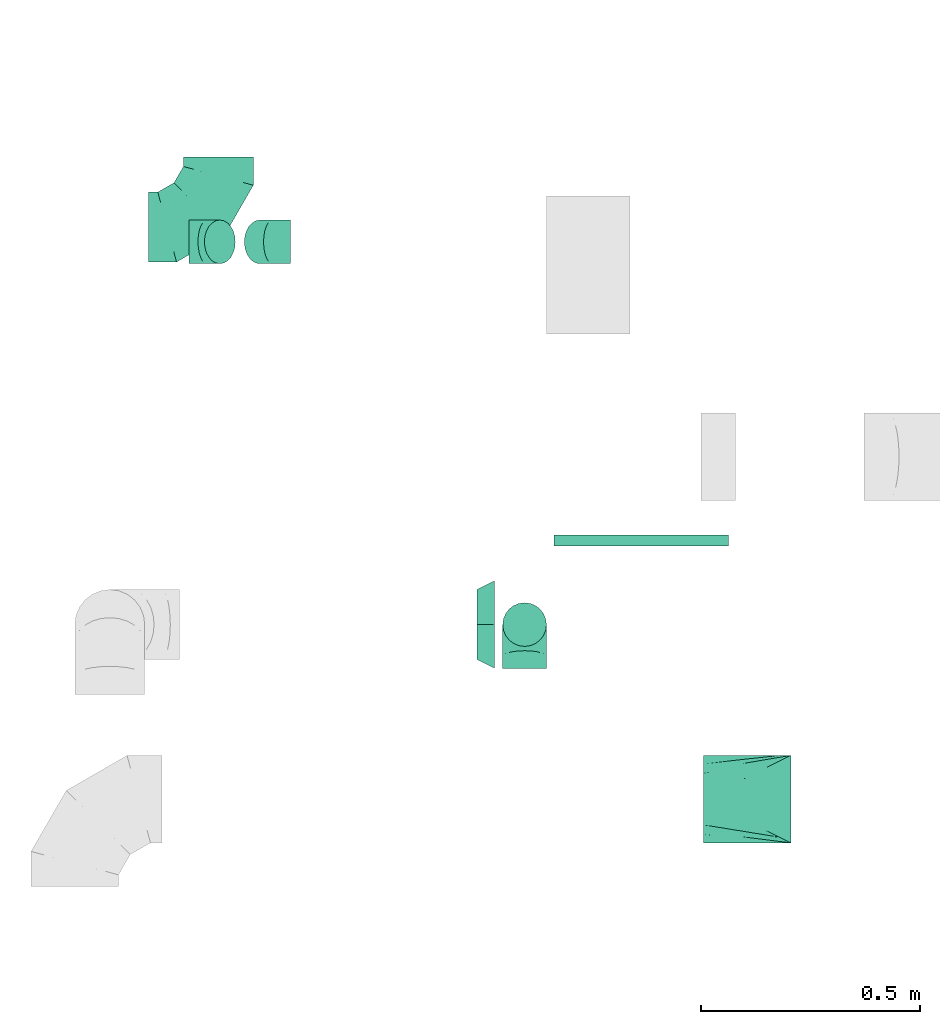
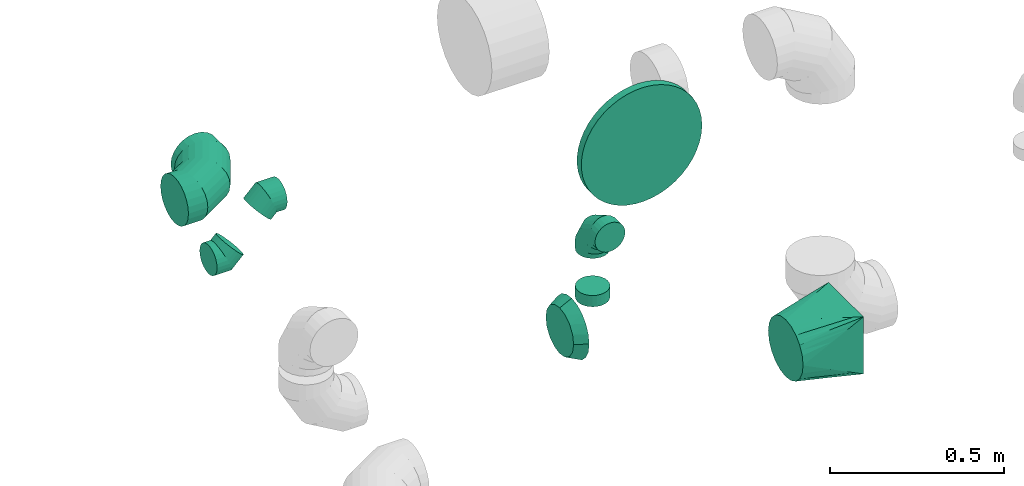
# One storey, part 19 of 62: 8 flow fittings.
"""IFC2X3 building model written with IfcOpenShell, lengths in millimetres."""

from ifc_helpers import new_model, entity, si_unit, converted_unit, derived_unit, direction, frame, origin, origin_2d_with_axis, place, context, subcontext, project, spatial, circle, extrude, faceted_brep, source, transform, mapped, material, type_object, type_shapes, element, save


model = new_model("IFC2X3")

# Units and contexts
model_context = context("Model", 3, precision=0.01, world=origin(), true_north=direction((6.12303176911189e-17, 1.0)))
body_context = subcontext(model_context, "Body", "Model", "MODEL_VIEW")
ifc_project = project(units=[si_unit("LENGTHUNIT", "METRE", prefix="MILLI"), si_unit("AREAUNIT", "SQUARE_METRE"), si_unit("VOLUMEUNIT", "CUBIC_METRE"), converted_unit("PLANEANGLEUNIT", "DEGREE", entity("IfcRatioMeasure", 0.0174532925199433), si_unit("PLANEANGLEUNIT", "RADIAN"), dimensions=[0, 0, 0, 0, 0, 0, 0]), si_unit("MASSUNIT", "GRAM", prefix="KILO"), derived_unit("MASSDENSITYUNIT", [(si_unit("MASSUNIT", "GRAM", prefix="KILO"), 1), (si_unit("LENGTHUNIT", "METRE"), -3)]), derived_unit("MOMENTOFINERTIAUNIT", [(si_unit("LENGTHUNIT", "METRE"), 4)]), si_unit("TIMEUNIT", "SECOND"), si_unit("FREQUENCYUNIT", "HERTZ"), si_unit("THERMODYNAMICTEMPERATUREUNIT", "DEGREE_CELSIUS"), derived_unit("THERMALTRANSMITTANCEUNIT", [(si_unit("MASSUNIT", "GRAM", prefix="KILO"), 1), (si_unit("THERMODYNAMICTEMPERATUREUNIT", "KELVIN"), -1), (si_unit("TIMEUNIT", "SECOND"), -3)]), derived_unit("VOLUMETRICFLOWRATEUNIT", [(si_unit("LENGTHUNIT", "METRE"), 3), (si_unit("TIMEUNIT", "SECOND"), -1)]), derived_unit("MASSFLOWRATEUNIT", [(si_unit("MASSUNIT", "GRAM", prefix="KILO"), 1), (si_unit("TIMEUNIT", "SECOND"), -1)]), derived_unit("ROTATIONALFREQUENCYUNIT", [(si_unit("TIMEUNIT", "SECOND"), -1)]), si_unit("ELECTRICCURRENTUNIT", "AMPERE"), si_unit("ELECTRICVOLTAGEUNIT", "VOLT"), si_unit("POWERUNIT", "WATT"), si_unit("FORCEUNIT", "NEWTON", prefix="KILO"), si_unit("ILLUMINANCEUNIT", "LUX"), si_unit("LUMINOUSFLUXUNIT", "LUMEN"), si_unit("LUMINOUSINTENSITYUNIT", "CANDELA"), derived_unit("USERDEFINED", [(si_unit("MASSUNIT", "GRAM", prefix="KILO"), -1), (si_unit("LENGTHUNIT", "METRE"), -2), (si_unit("TIMEUNIT", "SECOND"), 3), (si_unit("LUMINOUSFLUXUNIT", "LUMEN"), 1)]), derived_unit("LINEARVELOCITYUNIT", [(si_unit("LENGTHUNIT", "METRE"), 1), (si_unit("TIMEUNIT", "SECOND"), -1)]), si_unit("PRESSUREUNIT", "PASCAL"), derived_unit("USERDEFINED", [(si_unit("LENGTHUNIT", "METRE"), -2), (si_unit("MASSUNIT", "GRAM", prefix="KILO"), 1), (si_unit("TIMEUNIT", "SECOND"), -2)]), derived_unit("LINEARFORCEUNIT", [(si_unit("MASSUNIT", "GRAM", prefix="KILO"), 1), (si_unit("LENGTHUNIT", "METRE"), 1), (si_unit("TIMEUNIT", "SECOND"), -2), (si_unit("LENGTHUNIT", "METRE"), -1)]), derived_unit("PLANARFORCEUNIT", [(si_unit("MASSUNIT", "GRAM", prefix="KILO"), 1), (si_unit("LENGTHUNIT", "METRE"), 1), (si_unit("TIMEUNIT", "SECOND"), -2), (si_unit("LENGTHUNIT", "METRE"), -2)])], contexts=[model_context])

# Site, building, storey
site_placement = place(None, origin())
site = spatial("IfcSite", under=ifc_project, at=site_placement, CompositionType="ELEMENT")
building_placement = place(site_placement, origin())
building = spatial("IfcBuilding", under=site, at=building_placement, CompositionType="ELEMENT")
storey_placement = place(building_placement, frame((0.0, 0.0, 24000.0)))
storey = spatial("IfcBuildingStorey", under=building, at=storey_placement, CompositionType="ELEMENT", Elevation=24000.0)

# Flow fittings
ifc_material = material()
duct_fitting_type_1 = type_object("IfcDuctFittingType", PredefinedType="NOTDEFINED", material=ifc_material)
shared_shape_1 = source(origin(), body_context, "Body", "SweptSolid", [
    extrude(circle(Radius=199.999999999999, at=origin_2d_with_axis()), frame((0.0, 0.0, 0.0), z_axis=(1.0, 0.0, 0.0), x_axis=(0.0, 1.0, 0.0)), (0.0, 0.0, 1.0), 25.0000000000018),
])
type_shapes(duct_fitting_type_1, [shared_shape_1])
flow_fitting_1_placement = place(storey_placement, frame((24329.3, 9529.36, 3560.0), z_axis=(0.0, 0.0, 1.0), x_axis=(0.0, -1.0, 0.0)))
element("IfcFlowFitting", 1, at=flow_fitting_1_placement, inside=storey, type_object=duct_fitting_type_1, material=ifc_material, context=body_context, shape_type="MappedRepresentation", body=[
    mapped(shared_shape_1, transform((0.0, 0.0, 0.0), scale=1.0)),
])
duct_fitting_type_2 = type_object("IfcDuctFittingType", PredefinedType="NOTDEFINED", material=ifc_material)
shared_shape_2 = source(origin(), body_context, "Body", "Brep", [
    faceted_brep([(-160.0, 0.0, -80.0), (-160.0, -20.71, -77.27), (-160.0, -40.0, -69.28), (-160.0, -56.57, -56.57), (-160.0, -69.28, -40.0), (-160.0, -77.27, -20.71), (-160.0, -80.0, 0.0), (-160.0, -77.27, 20.71), (-160.0, -69.28, 40.0), (-160.0, -56.57, 56.57), (-160.0, -40.0, 69.28), (-160.0, -20.71, 77.27), (-160.0, 0.0, 80.0), (-160.0, 20.71, 77.27), (-160.0, 40.0, 69.28), (-160.0, 56.57, 56.57), (-160.0, 69.28, 40.0), (-160.0, 77.27, 20.71), (-160.0, 80.0, 0.0), (-160.0, 77.27, -20.71), (-160.0, 69.28, -40.0), (-160.0, 56.57, -56.57), (-160.0, 40.0, -69.28), (-160.0, 20.71, -77.27), (-122.68, 20.71, 77.27), (-127.85, 40.0, 69.28), (-117.13, 0.0, 80.0), (-132.29, 56.57, 56.57), (-137.83, 77.27, 20.71), (-138.56, 80.0, 0.0), (-135.69, 69.28, 40.0), (-135.69, 69.28, -40.0), (-132.29, 56.57, -56.57), (-137.83, 77.27, -20.71), (-122.68, 20.71, -77.27), (-117.13, 0.0, -80.0), (-127.85, 40.0, -69.28), (-111.58, -20.71, -77.27), (-106.41, -40.0, -69.28), (-101.97, -56.57, -56.57), (-98.56, -69.28, -40.0), (-96.42, -77.27, -20.71), (-95.69, -80.0, 0.0), (-96.42, -77.27, 20.71), (-98.56, -69.28, 40.0), (-101.97, -56.57, 56.57), (-106.41, -40.0, 69.28), (-111.58, -20.71, 77.27), (-58.03, 58.03, 77.27), (-72.15, 72.15, 69.28), (-42.87, 42.87, 80.0), (-84.28, 84.28, 56.57), (-93.59, 93.59, 40.0), (-99.44, 99.44, 20.71), (-101.44, 101.44, 0.0), (-99.44, 99.44, -20.71), (-93.59, 93.59, -40.0), (-84.28, 84.28, -56.57), (-58.03, 58.03, -77.27), (-42.87, 42.87, -80.0), (-72.15, 72.15, -69.28), (-27.71, 27.71, -77.27), (-13.59, 13.59, -69.28), (-1.46, 1.46, -56.57), (7.85, -7.85, -40.0), (13.7, -13.7, -20.71), (15.69, -15.69, 0.0), (13.7, -13.7, 20.71), (7.85, -7.85, 40.0), (-1.46, 1.46, 56.57), (-13.59, 13.59, 69.28), (-27.71, 27.71, 77.27), (-20.71, 122.68, 77.27), (-40.0, 127.85, 69.28), (0.0, 117.13, 80.0), (-56.57, 132.29, 56.57), (-69.28, 135.69, 40.0), (-77.27, 137.83, 20.71), (-80.0, 138.56, 0.0), (-77.27, 137.83, -20.71), (-69.28, 135.69, -40.0), (-56.57, 132.29, -56.57), (-20.71, 122.68, -77.27), (0.0, 117.13, -80.0), (-40.0, 127.85, -69.28), (20.71, 111.58, -77.27), (40.0, 106.41, -69.28), (56.57, 101.97, -56.57), (69.28, 98.56, -40.0), (77.27, 96.42, -20.71), (80.0, 95.69, 0.0), (77.27, 96.42, 20.71), (69.28, 98.56, 40.0), (56.57, 101.97, 56.57), (40.0, 106.41, 69.28), (20.71, 111.58, 77.27), (-20.71, 160.0, -77.27), (-40.0, 160.0, -69.28), (-56.57, 160.0, -56.57), (-69.28, 160.0, -40.0), (-77.27, 160.0, -20.71), (-80.0, 160.0, 0.0), (-77.27, 160.0, 20.71), (-69.28, 160.0, 40.0), (-56.57, 160.0, 56.57), (-40.0, 160.0, 69.28), (-20.71, 160.0, 77.27), (0.0, 160.0, 80.0), (20.71, 160.0, 77.27), (40.0, 160.0, 69.28), (56.57, 160.0, 56.57), (69.28, 160.0, 40.0), (77.27, 160.0, 20.71), (80.0, 160.0, 0.0), (77.27, 160.0, -20.71), (69.28, 160.0, -40.0), (56.57, 160.0, -56.57), (40.0, 160.0, -69.28), (20.71, 160.0, -77.27), (0.0, 160.0, -80.0)], [[[0, 1, 2, 3, 4, 5, 6, 7, 8, 9, 10, 11, 12, 13, 14, 15, 16, 17, 18, 19, 20, 21, 22, 23]], [[24, 25, 14, 13]], [[26, 24, 13, 12]], [[14, 25, 27, 15]], [[28, 29, 18, 17]], [[30, 28, 17, 16]], [[15, 27, 30, 16]], [[20, 31, 32, 21]], [[33, 31, 20, 19]], [[18, 29, 33, 19]], [[34, 35, 0, 23]], [[36, 34, 23, 22]], [[32, 36, 22, 21]], [[1, 0, 35, 37]], [[2, 1, 37, 38]], [[3, 2, 38, 39]], [[5, 4, 40, 41]], [[6, 5, 41, 42]], [[39, 40, 4, 3]], [[6, 42, 43, 7]], [[7, 43, 44, 8]], [[8, 44, 45, 9]], [[9, 45, 46, 10]], [[10, 46, 47, 11]], [[26, 12, 11, 47]], [[48, 49, 25, 24]], [[50, 48, 24, 26]], [[27, 25, 49, 51]], [[52, 53, 28, 30]], [[51, 52, 30, 27]], [[29, 28, 53, 54]], [[55, 56, 31, 33]], [[54, 55, 33, 29]], [[32, 31, 56, 57]], [[58, 59, 35, 34]], [[60, 58, 34, 36]], [[57, 60, 36, 32]], [[37, 35, 59, 61]], [[38, 37, 61, 62]], [[39, 38, 62, 63]], [[41, 40, 64, 65]], [[42, 41, 65, 66]], [[63, 64, 40, 39]], [[43, 42, 66, 67]], [[44, 43, 67, 68]], [[68, 69, 45, 44]], [[46, 45, 69, 70]], [[47, 46, 70, 71]], [[26, 47, 71, 50]], [[72, 73, 49, 48]], [[74, 72, 48, 50]], [[51, 49, 73, 75]], [[76, 77, 53, 52]], [[75, 76, 52, 51]], [[54, 53, 77, 78]], [[79, 80, 56, 55]], [[78, 79, 55, 54]], [[57, 56, 80, 81]], [[82, 83, 59, 58]], [[84, 82, 58, 60]], [[81, 84, 60, 57]], [[61, 59, 83, 85]], [[62, 61, 85, 86]], [[63, 62, 86, 87]], [[65, 64, 88, 89]], [[66, 65, 89, 90]], [[87, 88, 64, 63]], [[67, 66, 90, 91]], [[68, 67, 91, 92]], [[92, 93, 69, 68]], [[70, 69, 93, 94]], [[71, 70, 94, 95]], [[50, 71, 95, 74]], [[96, 97, 98, 99, 100, 101, 102, 103, 104, 105, 106, 107, 108, 109, 110, 111, 112, 113, 114, 115, 116, 117, 118, 119]], [[72, 74, 107, 106]], [[73, 72, 106, 105]], [[75, 73, 105, 104]], [[77, 76, 103, 102]], [[78, 77, 102, 101]], [[75, 104, 103, 76]], [[78, 101, 100, 79]], [[79, 100, 99, 80]], [[80, 99, 98, 81]], [[84, 97, 96, 82]], [[82, 96, 119, 83]], [[84, 81, 98, 97]], [[118, 117, 86, 85]], [[119, 118, 85, 83]], [[116, 87, 86, 117]], [[88, 115, 114, 89]], [[89, 114, 113, 90]], [[115, 88, 87, 116]], [[112, 111, 92, 91]], [[113, 112, 91, 90]], [[111, 110, 93, 92]], [[95, 94, 109, 108]], [[74, 95, 108, 107]], [[110, 109, 94, 93]]]),
])
type_shapes(duct_fitting_type_2, [shared_shape_2])
flow_fitting_2_placement = place(storey_placement, frame((23362.42, 10233.8, 3320.0)))
element("IfcFlowFitting", 2, at=flow_fitting_2_placement, inside=storey, type_object=duct_fitting_type_2, material=ifc_material, context=body_context, shape_type="MappedRepresentation", body=[
    mapped(shared_shape_2, transform((0.0, 0.0, 0.0), scale=1.0)),
])
duct_fitting_type_3 = type_object("IfcDuctFittingType", PredefinedType="NOTDEFINED", material=ifc_material)
shared_shape_3 = source(origin(), body_context, "Body", "Brep", [
    faceted_brep([(-100.0, 0.0, -50.0), (-100.0, -12.94, -48.3), (-100.0, -25.0, -43.3), (-100.0, -35.36, -35.36), (-100.0, -43.3, -25.0), (-100.0, -48.3, -12.94), (-100.0, -50.0, 0.0), (-100.0, -48.3, 12.94), (-100.0, -43.3, 25.0), (-100.0, -35.36, 35.36), (-100.0, -25.0, 43.3), (-100.0, -12.94, 48.3), (-100.0, 0.0, 50.0), (-100.0, 12.94, 48.3), (-100.0, 25.0, 43.3), (-100.0, 35.36, 35.36), (-100.0, 43.3, 25.0), (-100.0, 48.3, 12.94), (-100.0, 50.0, 0.0), (-100.0, 48.3, -12.94), (-100.0, 43.3, -25.0), (-100.0, 35.36, -35.36), (-100.0, 25.0, -43.3), (-100.0, 12.94, -48.3), (-76.67, 12.94, 48.3), (-79.9, 25.0, 43.3), (-73.21, 0.0, 50.0), (-82.68, 35.36, 35.36), (-86.15, 48.3, 12.94), (-86.6, 50.0, 0.0), (-84.81, 43.3, 25.0), (-84.81, 43.3, -25.0), (-82.68, 35.36, -35.36), (-86.15, 48.3, -12.94), (-76.67, 12.94, -48.3), (-73.21, 0.0, -50.0), (-79.9, 25.0, -43.3), (-69.74, -12.94, -48.3), (-66.51, -25.0, -43.3), (-63.73, -35.36, -35.36), (-61.6, -43.3, -25.0), (-60.26, -48.3, -12.94), (-59.81, -50.0, 0.0), (-60.26, -48.3, 12.94), (-61.6, -43.3, 25.0), (-63.73, -35.36, 35.36), (-66.51, -25.0, 43.3), (-69.74, -12.94, 48.3), (-36.27, 36.27, 48.3), (-45.1, 45.1, 43.3), (-26.79, 26.79, 50.0), (-52.68, 52.68, 35.36), (-58.49, 58.49, 25.0), (-62.15, 62.15, 12.94), (-63.4, 63.4, 0.0), (-62.15, 62.15, -12.94), (-58.49, 58.49, -25.0), (-52.68, 52.68, -35.36), (-36.27, 36.27, -48.3), (-26.79, 26.79, -50.0), (-45.1, 45.1, -43.3), (-17.32, 17.32, -48.3), (-8.49, 8.49, -43.3), (-0.91, 0.91, -35.36), (4.9, -4.9, -25.0), (8.56, -8.56, -12.94), (9.81, -9.81, 0.0), (8.56, -8.56, 12.94), (4.9, -4.9, 25.0), (-0.91, 0.91, 35.36), (-8.49, 8.49, 43.3), (-17.32, 17.32, 48.3), (-12.94, 76.67, 48.3), (-25.0, 79.9, 43.3), (0.0, 73.21, 50.0), (-35.36, 82.68, 35.36), (-43.3, 84.81, 25.0), (-48.3, 86.15, 12.94), (-50.0, 86.6, 0.0), (-48.3, 86.15, -12.94), (-43.3, 84.81, -25.0), (-35.36, 82.68, -35.36), (-12.94, 76.67, -48.3), (0.0, 73.21, -50.0), (-25.0, 79.9, -43.3), (12.94, 69.74, -48.3), (25.0, 66.51, -43.3), (35.36, 63.73, -35.36), (43.3, 61.6, -25.0), (48.3, 60.26, -12.94), (50.0, 59.81, 0.0), (48.3, 60.26, 12.94), (43.3, 61.6, 25.0), (35.36, 63.73, 35.36), (25.0, 66.51, 43.3), (12.94, 69.74, 48.3), (-12.94, 100.0, -48.3), (-25.0, 100.0, -43.3), (-35.36, 100.0, -35.36), (-43.3, 100.0, -25.0), (-48.3, 100.0, -12.94), (-50.0, 100.0, 0.0), (-48.3, 100.0, 12.94), (-43.3, 100.0, 25.0), (-35.36, 100.0, 35.36), (-25.0, 100.0, 43.3), (-12.94, 100.0, 48.3), (0.0, 100.0, 50.0), (12.94, 100.0, 48.3), (25.0, 100.0, 43.3), (35.36, 100.0, 35.36), (43.3, 100.0, 25.0), (48.3, 100.0, 12.94), (50.0, 100.0, 0.0), (48.3, 100.0, -12.94), (43.3, 100.0, -25.0), (35.36, 100.0, -35.36), (25.0, 100.0, -43.3), (12.94, 100.0, -48.3), (0.0, 100.0, -50.0)], [[[0, 1, 2, 3, 4, 5, 6, 7, 8, 9, 10, 11, 12, 13, 14, 15, 16, 17, 18, 19, 20, 21, 22, 23]], [[24, 25, 14, 13]], [[26, 24, 13, 12]], [[14, 25, 27, 15]], [[28, 29, 18, 17]], [[30, 28, 17, 16]], [[15, 27, 30, 16]], [[20, 31, 32, 21]], [[33, 31, 20, 19]], [[18, 29, 33, 19]], [[34, 35, 0, 23]], [[36, 34, 23, 22]], [[32, 36, 22, 21]], [[2, 1, 37, 38]], [[3, 2, 38, 39]], [[0, 35, 37, 1]], [[5, 4, 40, 41]], [[6, 5, 41, 42]], [[3, 39, 40, 4]], [[6, 42, 43, 7]], [[7, 43, 44, 8]], [[8, 44, 45, 9]], [[10, 46, 47, 11]], [[11, 47, 26, 12]], [[10, 9, 45, 46]], [[48, 49, 25, 24]], [[50, 48, 24, 26]], [[27, 25, 49, 51]], [[52, 53, 28, 30]], [[51, 52, 30, 27]], [[29, 28, 53, 54]], [[55, 56, 31, 33]], [[54, 55, 33, 29]], [[57, 32, 31, 56]], [[58, 59, 35, 34]], [[60, 58, 34, 36]], [[57, 60, 36, 32]], [[37, 35, 59, 61]], [[38, 37, 61, 62]], [[39, 38, 62, 63]], [[41, 40, 64, 65]], [[42, 41, 65, 66]], [[63, 64, 40, 39]], [[43, 42, 66, 67]], [[44, 43, 67, 68]], [[68, 69, 45, 44]], [[46, 45, 69, 70]], [[47, 46, 70, 71]], [[26, 47, 71, 50]], [[72, 73, 49, 48]], [[74, 72, 48, 50]], [[51, 49, 73, 75]], [[76, 77, 53, 52]], [[75, 76, 52, 51]], [[54, 53, 77, 78]], [[79, 80, 56, 55]], [[78, 79, 55, 54]], [[81, 57, 56, 80]], [[82, 83, 59, 58]], [[84, 82, 58, 60]], [[81, 84, 60, 57]], [[61, 59, 83, 85]], [[62, 61, 85, 86]], [[63, 62, 86, 87]], [[65, 64, 88, 89]], [[66, 65, 89, 90]], [[87, 88, 64, 63]], [[67, 66, 90, 91]], [[68, 67, 91, 92]], [[92, 93, 69, 68]], [[70, 69, 93, 94]], [[71, 70, 94, 95]], [[50, 71, 95, 74]], [[96, 97, 98, 99, 100, 101, 102, 103, 104, 105, 106, 107, 108, 109, 110, 111, 112, 113, 114, 115, 116, 117, 118, 119]], [[72, 74, 107, 106]], [[73, 72, 106, 105]], [[75, 73, 105, 104]], [[77, 76, 103, 102]], [[78, 77, 102, 101]], [[75, 104, 103, 76]], [[78, 101, 100, 79]], [[79, 100, 99, 80]], [[80, 99, 98, 81]], [[96, 119, 83, 82]], [[97, 96, 82, 84]], [[84, 81, 98, 97]], [[83, 119, 118, 85]], [[85, 118, 117, 86]], [[86, 117, 116, 87]], [[88, 115, 114, 89]], [[89, 114, 113, 90]], [[87, 116, 115, 88]], [[91, 90, 113, 112]], [[92, 91, 112, 111]], [[93, 92, 111, 110]], [[95, 94, 109, 108]], [[74, 95, 108, 107]], [[110, 109, 94, 93]]]),
])
type_shapes(duct_fitting_type_3, [shared_shape_3])
flow_fitting_3_placement = place(storey_placement, frame((24062.93, 9324.41, 3500.0), z_axis=(1.0, 0.0, 0.0), x_axis=(0.0, 0.0, 1.0)))
element("IfcFlowFitting", 3, at=flow_fitting_3_placement, inside=storey, type_object=duct_fitting_type_3, material=ifc_material, context=body_context, shape_type="MappedRepresentation", body=[
    mapped(shared_shape_3, transform((0.0, 0.0, 0.0), scale=1.0)),
])
duct_fitting_type_4 = type_object("IfcDuctFittingType", PredefinedType="NOTDEFINED", material=ifc_material)
shared_shape_4 = source(origin(), body_context, "Body", "Brep", [
    faceted_brep([(-41.42, 0.0, -50.0), (-41.42, -12.94, -48.3), (-41.42, -25.0, -43.3), (-41.42, -35.36, -35.36), (-41.42, -43.3, -25.0), (-41.42, -48.3, -12.94), (-41.42, -50.0, 0.0), (-41.42, -48.3, 12.94), (-41.42, -43.3, 25.0), (-41.42, -35.36, 35.36), (-41.42, -25.0, 43.3), (-41.42, -12.94, 48.3), (-41.42, 0.0, 50.0), (-41.42, 12.94, 48.3), (-41.42, 25.0, 43.3), (-41.42, 35.36, 35.36), (-41.42, 43.3, 25.0), (-41.42, 48.3, 12.94), (-41.42, 50.0, 0.0), (-41.42, 48.3, -12.94), (-41.42, 43.3, -25.0), (-41.42, 35.36, -35.36), (-41.42, 25.0, -43.3), (-41.42, 12.94, -48.3), (-5.36, 12.94, 48.3), (-10.36, 25.0, 43.3), (0.0, 0.0, 50.0), (-14.64, 35.36, 35.36), (-20.0, 48.3, 12.94), (-20.71, 50.0, 0.0), (-17.94, 43.3, 25.0), (-17.94, 43.3, -25.0), (-14.64, 35.36, -35.36), (-20.0, 48.3, -12.94), (-5.36, 12.94, -48.3), (0.0, 0.0, -50.0), (-10.36, 25.0, -43.3), (5.36, -12.94, -48.3), (10.36, -25.0, -43.3), (14.64, -35.36, -35.36), (17.94, -43.3, -25.0), (20.0, -48.3, -12.94), (20.71, -50.0, 0.0), (20.0, -48.3, 12.94), (17.94, -43.3, 25.0), (14.64, -35.36, 35.36), (10.36, -25.0, 43.3), (5.36, -12.94, 48.3), (29.29, 29.29, 50.0), (20.14, 38.44, 48.3), (11.61, 46.97, 43.3), (4.29, 54.29, 35.36), (-1.33, 59.91, 25.0), (-4.86, 63.44, 12.94), (-6.07, 64.64, 0.0), (-4.86, 63.44, -12.94), (-1.33, 59.91, -25.0), (4.29, 54.29, -35.36), (11.61, 46.97, -43.3), (20.14, 38.44, -48.3), (29.29, 29.29, -50.0), (38.44, 20.14, -48.3), (46.97, 11.61, -43.3), (54.29, 4.29, -35.36), (59.91, -1.33, -25.0), (63.44, -4.86, -12.94), (64.64, -6.07, 0.0), (63.44, -4.86, 12.94), (59.91, -1.33, 25.0), (54.29, 4.29, 35.36), (46.97, 11.61, 43.3), (38.44, 20.14, 48.3)], [[[0, 1, 2, 3, 4, 5, 6, 7, 8, 9, 10, 11, 12, 13, 14, 15, 16, 17, 18, 19, 20, 21, 22, 23]], [[24, 25, 14, 13]], [[26, 24, 13, 12]], [[14, 25, 27, 15]], [[28, 29, 18, 17]], [[30, 28, 17, 16]], [[16, 15, 27, 30]], [[20, 31, 32, 21]], [[33, 31, 20, 19]], [[18, 29, 33, 19]], [[34, 35, 0, 23]], [[36, 34, 23, 22]], [[32, 36, 22, 21]], [[1, 0, 35, 37]], [[2, 1, 37, 38]], [[38, 39, 3, 2]], [[5, 4, 40, 41]], [[6, 5, 41, 42]], [[39, 40, 4, 3]], [[6, 42, 43, 7]], [[7, 43, 44, 8]], [[8, 44, 45, 9]], [[9, 45, 46, 10]], [[10, 46, 47, 11]], [[26, 12, 11, 47]], [[24, 26, 48, 49]], [[25, 24, 49, 50]], [[27, 25, 50, 51]], [[28, 30, 52, 53]], [[29, 28, 53, 54]], [[27, 51, 52, 30]], [[29, 54, 55, 33]], [[33, 55, 56, 31]], [[31, 56, 57, 32]], [[36, 58, 59, 34]], [[34, 59, 60, 35]], [[36, 32, 57, 58]], [[61, 62, 38, 37]], [[60, 61, 37, 35]], [[63, 39, 38, 62]], [[40, 64, 65, 41]], [[41, 65, 66, 42]], [[64, 40, 39, 63]], [[43, 42, 66, 67]], [[44, 43, 67, 68]], [[68, 69, 45, 44]], [[47, 46, 70, 71]], [[26, 47, 71, 48]], [[69, 70, 46, 45]], [[59, 58, 57, 56, 55, 54, 53, 52, 51, 50, 49, 48, 71, 70, 69, 68, 67, 66, 65, 64, 63, 62, 61, 60]]]),
])
type_shapes(duct_fitting_type_4, [shared_shape_4])
for number, where, z_axis, x_axis in (
    (4, (23336.45, 10199.94, 3100.0), (0.0, -1.0, 0.0), (1.0, 0.0, 0.0)),
    (5, (23486.45, 10199.94, 3250.0), (0.0, 1.0, 0.0), (0.707106781186481, 0.0, 0.707106781186615)),
):
    element("IfcFlowFitting", number, at=place(storey_placement, frame(where, z_axis=z_axis, x_axis=x_axis)), inside=storey, type_object=duct_fitting_type_4, material=ifc_material, context=body_context, shape_type="MappedRepresentation", body=[
        mapped(shared_shape_4, transform((0.0, 0.0, 0.0), scale=1.0)),
    ])
duct_fitting_type_5 = type_object("IfcDuctFittingType", PredefinedType="NOTDEFINED", material=ifc_material)
shared_shape_5 = source(origin(), body_context, "Body", "Brep", [
    faceted_brep([(40.0, -73.91, 30.61), (40.0, -76.96, 15.31), (40.0, -80.0, 0.0), (40.0, -76.96, -15.31), (40.0, -73.91, -30.61), (40.0, -65.24, -43.59), (40.0, -56.57, -56.57), (40.0, -43.59, -65.24), (40.0, -30.61, -73.91), (40.0, -15.31, -76.96), (40.0, 0.0, -80.0), (40.0, 15.31, -76.96), (40.0, 30.61, -73.91), (40.0, 43.59, -65.24), (40.0, 56.57, -56.57), (40.0, 65.24, -43.59), (40.0, 73.91, -30.61), (40.0, 76.96, -15.31), (40.0, 80.0, 0.0), (40.0, 76.96, 15.31), (40.0, 73.91, 30.61), (40.0, 65.24, 43.59), (40.0, 56.57, 56.57), (40.0, 43.59, 65.24), (40.0, 30.61, 73.91), (40.0, 15.31, 76.96), (40.0, 0.0, 80.0), (40.0, -15.31, 76.96), (40.0, -30.61, 73.91), (40.0, -43.59, 65.24), (40.0, -56.57, 56.57), (40.0, -65.24, 43.59), (0.0, -100.0, 0.0), (0.0, -95.11, 30.9), (0.0, -80.9, 58.78), (0.0, -58.78, 80.9), (0.0, -30.9, 95.11), (0.0, 0.0, 100.0), (0.0, 30.9, 95.11), (0.0, 58.78, 80.9), (0.0, 80.9, 58.78), (0.0, 95.11, 30.9), (0.0, 100.0, 0.0), (0.0, 95.11, -30.9), (0.0, 80.9, -58.78), (0.0, 58.78, -80.9), (0.0, 30.9, -95.11), (0.0, 0.0, -100.0), (0.0, -30.9, -95.11), (0.0, -58.78, -80.9), (0.0, -80.9, -58.78), (0.0, -95.11, -30.9)], [[[0, 1, 2, 3, 4, 5, 6, 7, 8, 9, 10, 11, 12, 13, 14, 15, 16, 17, 18, 19, 20, 21, 22, 23, 24, 25, 26, 27, 28, 29, 30, 31]], [[32, 33, 34, 35, 36, 37, 38, 39, 40, 41, 42, 43, 44, 45, 46, 47, 48, 49, 50, 51]], [[37, 25, 38]], [[25, 24, 38]], [[24, 39, 38]], [[41, 20, 19]], [[25, 37, 26]], [[39, 24, 23, 22]], [[42, 19, 18]], [[20, 40, 22, 21]], [[41, 40, 20]], [[42, 41, 19]], [[22, 40, 39]], [[32, 1, 33]], [[1, 0, 33]], [[0, 34, 33]], [[36, 28, 27]], [[1, 32, 2]], [[34, 0, 31, 30]], [[37, 27, 26]], [[28, 35, 30, 29]], [[36, 35, 28]], [[37, 36, 27]], [[30, 35, 34]], [[47, 9, 48]], [[9, 8, 48]], [[8, 49, 48]], [[51, 4, 3]], [[9, 47, 10]], [[49, 8, 7, 6]], [[32, 3, 2]], [[4, 50, 6, 5]], [[51, 50, 4]], [[32, 51, 3]], [[6, 50, 49]], [[42, 17, 43]], [[17, 16, 43]], [[16, 44, 43]], [[46, 12, 11]], [[17, 42, 18]], [[44, 16, 15, 14]], [[47, 11, 10]], [[12, 45, 14, 13]], [[46, 45, 12]], [[47, 46, 11]], [[14, 45, 44]]]),
])
type_shapes(duct_fitting_type_5, [shared_shape_5])
flow_fitting_4_placement = place(storey_placement, frame((23993.85, 9324.41, 3150.0), z_axis=(0.0, 0.0, 1.0), x_axis=(-1.0, 0.0, 0.0)))
element("IfcFlowFitting", 6, at=flow_fitting_4_placement, inside=storey, type_object=duct_fitting_type_5, material=ifc_material, context=body_context, shape_type="MappedRepresentation", body=[
    mapped(shared_shape_5, transform((0.0, 0.0, 0.0), scale=1.0)),
])
duct_fitting_type_6 = type_object("IfcDuctFittingType", PredefinedType="NOTDEFINED", material=ifc_material)
shared_shape_6 = source(origin(), body_context, "Body", "Brep", [
    faceted_brep([(20.0, 12.94, -48.3), (20.0, 25.0, -43.3), (20.0, 35.36, -35.36), (20.0, 43.3, -25.0), (20.0, 48.3, -12.94), (20.0, 50.0, 0.0), (20.0, 48.3, 12.94), (20.0, 43.3, 25.0), (20.0, 35.36, 35.36), (20.0, 25.0, 43.3), (20.0, 12.94, 48.3), (20.0, 0.0, 50.0), (20.0, -12.94, 48.3), (20.0, -25.0, 43.3), (20.0, -35.36, 35.36), (20.0, -43.3, 25.0), (20.0, -48.3, 12.94), (20.0, -50.0, 0.0), (20.0, -48.3, -12.94), (20.0, -43.3, -25.0), (20.0, -35.36, -35.36), (20.0, -25.0, -43.3), (20.0, -12.94, -48.3), (20.0, 0.0, -50.0), (0.0, 0.0, 50.0), (0.0, 12.94, 48.3), (-19.49, 12.94, 48.3), (-19.49, 0.0, 50.0), (0.0, 25.0, 43.3), (-19.49, 25.0, 43.3), (0.0, 35.36, 35.36), (-19.49, 35.36, 35.36), (0.0, 43.3, 25.0), (0.0, 48.3, 12.94), (-19.49, 48.3, 12.94), (-19.49, 43.3, 25.0), (0.0, 50.0, 0.0), (-19.49, 50.0, 0.0), (0.0, 48.3, -12.94), (-19.49, 48.3, -12.94), (0.0, 43.3, -25.0), (-19.49, 43.3, -25.0), (0.0, 35.36, -35.36), (-19.49, 35.36, -35.36), (0.0, 25.0, -43.3), (0.0, 12.94, -48.3), (-19.49, 12.94, -48.3), (-19.49, 25.0, -43.3), (0.0, 0.0, -50.0), (-19.49, 0.0, -50.0), (0.0, -12.94, -48.3), (-19.49, -12.94, -48.3), (0.0, -25.0, -43.3), (-19.49, -25.0, -43.3), (0.0, -35.36, -35.36), (-19.49, -35.36, -35.36), (0.0, -43.3, -25.0), (0.0, -48.3, -12.94), (-19.49, -48.3, -12.94), (-19.49, -43.3, -25.0), (0.0, -50.0, 0.0), (-19.49, -50.0, 0.0), (0.0, -48.3, 12.94), (-19.49, -48.3, 12.94), (0.0, -43.3, 25.0), (-19.49, -43.3, 25.0), (0.0, -35.36, 35.36), (-19.49, -35.36, 35.36), (0.0, -25.0, 43.3), (0.0, -12.94, 48.3), (-19.49, -12.94, 48.3), (-19.49, -25.0, 43.3)], [[[0, 1, 2, 3, 4, 5, 6, 7, 8, 9, 10, 11, 12, 13, 14, 15, 16, 17, 18, 19, 20, 21, 22, 23]], [[24, 11, 10, 25, 26, 27]], [[25, 10, 9, 28, 29, 26]], [[28, 9, 8, 30, 31, 29]], [[32, 7, 6, 33, 34, 35]], [[33, 6, 5, 36, 37, 34]], [[30, 8, 7, 32, 35, 31]], [[36, 5, 4, 38, 39, 37]], [[38, 4, 3, 40, 41, 39]], [[40, 3, 2, 42, 43, 41]], [[44, 1, 0, 45, 46, 47]], [[45, 0, 23, 48, 49, 46]], [[42, 2, 1, 44, 47, 43]], [[48, 23, 22, 50, 51, 49]], [[50, 22, 21, 52, 53, 51]], [[52, 21, 20, 54, 55, 53]], [[56, 19, 18, 57, 58, 59]], [[57, 18, 17, 60, 61, 58]], [[54, 20, 19, 56, 59, 55]], [[60, 17, 16, 62, 63, 61]], [[62, 16, 15, 64, 65, 63]], [[64, 15, 14, 66, 67, 65]], [[68, 13, 12, 69, 70, 71]], [[69, 12, 11, 24, 27, 70]], [[66, 14, 13, 68, 71, 67]], [[49, 51, 53, 55, 59, 58, 61, 63, 65, 67, 71, 70, 27, 26, 29, 31, 35, 34, 37, 39, 41, 43, 47, 46]]]),
])
type_shapes(duct_fitting_type_6, [shared_shape_6])
flow_fitting_5_placement = place(storey_placement, frame((24062.93, 9324.41, 3250.0), z_axis=(0.0, 1.0, 0.0), x_axis=(0.0, 0.0, 1.0)))
element("IfcFlowFitting", 7, at=flow_fitting_5_placement, inside=storey, type_object=duct_fitting_type_6, material=ifc_material, context=body_context, shape_type="MappedRepresentation", body=[
    mapped(shared_shape_6, transform((0.0, 0.0, 0.0), scale=1.0)),
])
duct_fitting_type_7 = type_object("IfcDuctFittingType", PredefinedType="NOTDEFINED", material=ifc_material)
shared_shape_7 = source(origin(), body_context, "Body", "Brep", [
    faceted_brep([(200.0, 30.9, 95.11), (200.0, 19.08, 96.98), (200.0, 9.54, 98.49), (200.0, 4.77, 99.24), (200.0, 0.0, 100.0), (200.0, -4.77, 99.24), (200.0, -9.54, 98.49), (200.0, -19.08, 96.98), (200.0, -30.9, 95.11), (200.0, -44.84, 88.0), (200.0, -58.78, 80.9), (200.0, -69.84, 69.84), (200.0, -80.9, 58.78), (200.0, -88.0, 44.84), (200.0, -95.11, 30.9), (200.0, -96.98, 19.08), (200.0, -98.49, 9.54), (200.0, -99.24, 4.77), (200.0, -100.0, 0.0), (200.0, -99.24, -4.77), (200.0, -98.49, -9.54), (200.0, -96.98, -19.08), (200.0, -95.11, -30.9), (200.0, -88.0, -44.84), (200.0, -80.9, -58.78), (200.0, -69.84, -69.84), (200.0, -58.78, -80.9), (200.0, -44.84, -88.0), (200.0, -30.9, -95.11), (200.0, -19.08, -96.98), (200.0, -9.54, -98.49), (200.0, -4.77, -99.24), (200.0, 0.0, -100.0), (200.0, 4.77, -99.24), (200.0, 9.54, -98.49), (200.0, 19.08, -96.98), (200.0, 30.9, -95.11), (200.0, 44.84, -88.0), (200.0, 58.78, -80.9), (200.0, 69.84, -69.84), (200.0, 80.9, -58.78), (200.0, 88.0, -44.84), (200.0, 95.11, -30.9), (200.0, 96.98, -19.08), (200.0, 98.49, -9.54), (200.0, 99.24, -4.77), (200.0, 100.0, 0.0), (200.0, 99.24, 4.77), (200.0, 98.49, 9.54), (200.0, 96.98, 19.08), (200.0, 95.11, 30.9), (200.0, 88.0, 44.84), (200.0, 80.9, 58.78), (200.0, 69.84, 69.84), (200.0, 58.78, 80.9), (200.0, 44.84, 88.0), (0.0, -100.0, 100.0), (0.0, 100.0, 100.0), (0.0, 100.0, -100.0), (0.0, -100.0, -100.0), (104.11, -47.94, 100.0), (100.0, -83.15, 87.43), (26.03, -86.99, 100.0), (78.09, -60.96, 100.0), (52.06, -73.97, 100.0), (188.01, -5.99, 100.0), (176.03, -11.99, 100.0), (152.06, -23.97, 100.0), (128.09, -35.96, 100.0), (52.06, -100.0, 73.97), (78.09, -100.0, 60.96), (104.11, -100.0, 47.94), (128.09, -100.0, 35.96), (152.06, -100.0, 23.97), (176.03, -100.0, 11.99), (188.01, -100.0, 5.99), (26.03, -100.0, 86.99), (26.03, -100.0, -86.99), (52.06, -100.0, -73.97), (78.09, -100.0, -60.96), (104.11, -100.0, -47.94), (128.09, -100.0, -35.96), (152.06, -100.0, -23.97), (176.03, -100.0, -11.99), (188.01, -100.0, -5.99), (100.0, -87.43, -83.15), (52.06, -73.97, -100.0), (78.09, -60.96, -100.0), (104.11, -47.94, -100.0), (128.09, -35.96, -100.0), (152.06, -23.97, -100.0), (176.03, -11.99, -100.0), (188.01, -5.99, -100.0), (26.03, -86.99, -100.0), (26.03, 86.99, -100.0), (52.06, 73.97, -100.0), (78.09, 60.96, -100.0), (104.11, 47.94, -100.0), (128.09, 35.96, -100.0), (152.06, 23.97, -100.0), (176.03, 11.99, -100.0), (188.01, 5.99, -100.0), (100.0, 83.15, -87.43), (52.06, 100.0, -73.97), (78.09, 100.0, -60.96), (104.11, 100.0, -47.94), (128.09, 100.0, -35.96), (152.06, 100.0, -23.97), (176.03, 100.0, -11.99), (188.01, 100.0, -5.99), (26.03, 100.0, -86.99), (26.03, 100.0, 86.99), (52.06, 100.0, 73.97), (78.09, 100.0, 60.96), (104.11, 100.0, 47.94), (128.09, 100.0, 35.96), (152.06, 100.0, 23.97), (176.03, 100.0, 11.99), (188.01, 100.0, 5.99), (100.0, 87.43, 83.15), (52.06, 73.97, 100.0), (78.09, 60.96, 100.0), (104.11, 47.94, 100.0), (128.09, 35.96, 100.0), (152.06, 23.97, 100.0), (176.03, 11.99, 100.0), (188.01, 5.99, 100.0), (26.03, 86.99, 100.0)], [[[0, 1, 2, 3, 4, 5, 6, 7, 8, 9, 10, 11, 12, 13, 14, 15, 16, 17, 18, 19, 20, 21, 22, 23, 24, 25, 26, 27, 28, 29, 30, 31, 32, 33, 34, 35, 36, 37, 38, 39, 40, 41, 42, 43, 44, 45, 46, 47, 48, 49, 50, 51, 52, 53, 54, 55]], [[56, 57, 58, 59]], [[60, 9, 8]], [[56, 61, 62]], [[9, 60, 63, 64]], [[65, 66, 67, 68, 60, 8, 7, 6, 5, 4]], [[62, 61, 10]], [[13, 69, 70, 71]], [[64, 10, 9]], [[14, 71, 72, 73, 74, 75, 18, 17, 16, 15]], [[12, 76, 69]], [[71, 14, 13]], [[61, 76, 11]], [[10, 64, 62]], [[76, 12, 11]], [[10, 61, 11]], [[61, 56, 76]], [[69, 13, 12]], [[75, 74, 73, 72, 71, 70, 69, 76, 56, 59, 77, 78, 79, 80, 81, 82, 83, 84, 18]], [[80, 23, 22]], [[59, 85, 77]], [[23, 80, 79, 78]], [[84, 83, 82, 81, 80, 22, 21, 20, 19, 18]], [[77, 85, 24]], [[27, 86, 87, 88]], [[78, 24, 23]], [[28, 88, 89, 90, 91, 92, 32, 31, 30, 29]], [[26, 93, 86]], [[88, 28, 27]], [[85, 93, 25]], [[24, 78, 77]], [[93, 26, 25]], [[24, 85, 25]], [[85, 59, 93]], [[86, 27, 26]], [[92, 91, 90, 89, 88, 87, 86, 93, 59, 58, 94, 95, 96, 97, 98, 99, 100, 101, 32]], [[97, 37, 36]], [[58, 102, 94]], [[37, 97, 96, 95]], [[101, 100, 99, 98, 97, 36, 35, 34, 33, 32]], [[94, 102, 38]], [[41, 103, 104, 105]], [[95, 38, 37]], [[42, 105, 106, 107, 108, 109, 46, 45, 44, 43]], [[40, 110, 103]], [[105, 42, 41]], [[102, 110, 39]], [[38, 95, 94]], [[110, 40, 39]], [[38, 102, 39]], [[102, 58, 110]], [[103, 41, 40]], [[58, 57, 111, 112, 113, 114, 115, 116, 117, 118, 46, 109, 108, 107, 106, 105, 104, 103, 110]], [[114, 51, 50]], [[57, 119, 111]], [[51, 114, 113, 112]], [[118, 117, 116, 115, 114, 50, 49, 48, 47, 46]], [[111, 119, 52]], [[55, 120, 121, 122]], [[112, 52, 51]], [[0, 122, 123, 124, 125, 126, 4, 3, 2, 1]], [[54, 127, 120]], [[122, 0, 55]], [[119, 127, 53]], [[52, 112, 111]], [[127, 54, 53]], [[52, 119, 53]], [[119, 57, 127]], [[120, 55, 54]], [[57, 56, 62, 64, 63, 60, 68, 67, 66, 65, 4, 126, 125, 124, 123, 122, 121, 120, 127]]]),
])
type_shapes(duct_fitting_type_7, [shared_shape_7])
flow_fitting_6_placement = place(storey_placement, frame((24671.92, 8924.98, 3150.0), z_axis=(0.0, 0.0, 1.0), x_axis=(-1.0, 0.0, 0.0)))
element("IfcFlowFitting", 8, at=flow_fitting_6_placement, inside=storey, type_object=duct_fitting_type_7, material=ifc_material, context=body_context, shape_type="MappedRepresentation", body=[
    mapped(shared_shape_7, transform((0.0, 0.0, 0.0), scale=1.0)),
])

save(model, "model.ifc")
